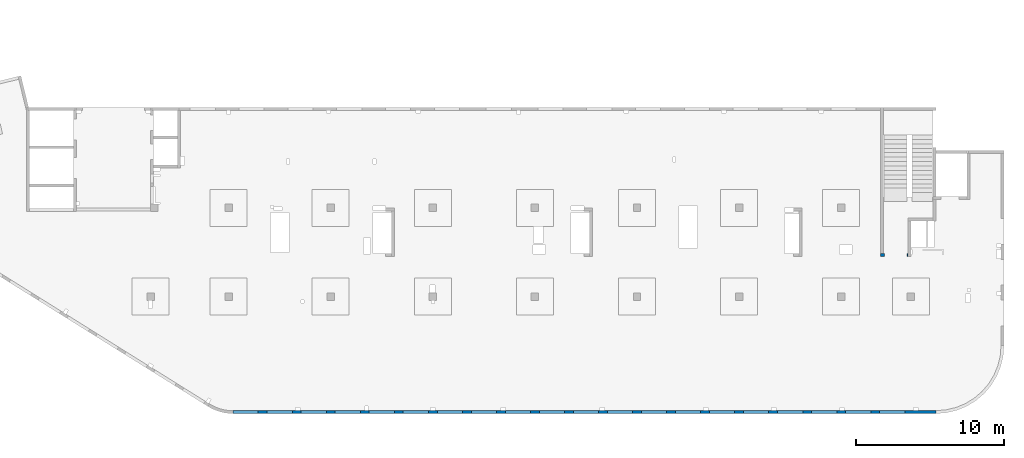
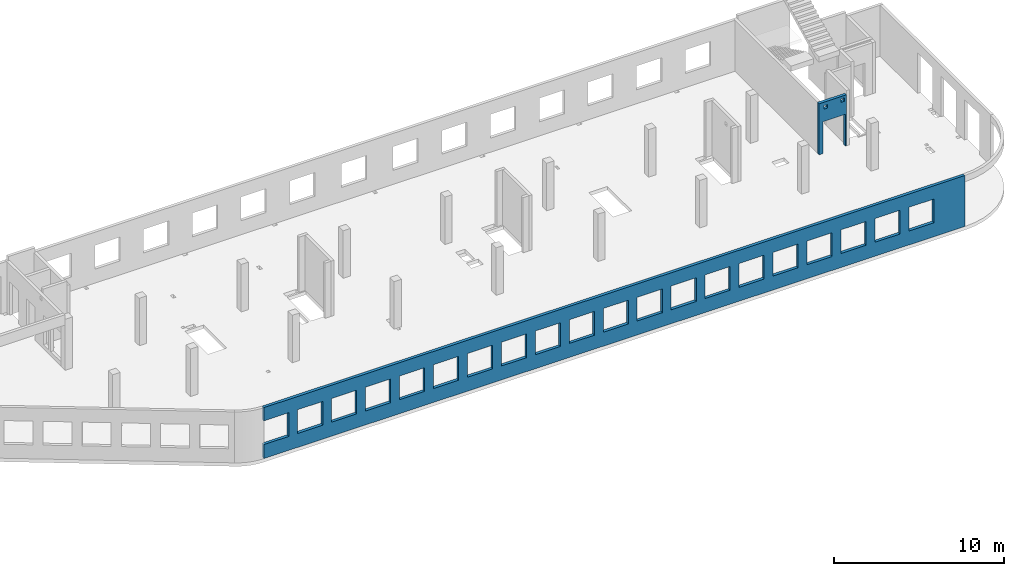
# One storey, part 91 of 93: 2 walls, 23 openings.
"""IFC4 building model written with IfcOpenShell, lengths in millimetres."""

import ifcopenshell
import ifcopenshell.guid

model = None  # the IFC model being written
_history = None  # IfcOwnerHistory: only IFC2X3 demands one
_inside = {}  # id of a spatial element -> (the spatial element, [elements in it])
_under = {}  # id of a project, library or spatial element -> (it, [spatial elements below it])
_declared = {}  # id of a project -> (the project, [libraries it declares])
_typed = {}  # id of a type object -> (the type object, [elements of that type])
_made_of = {}  # id of a material, layer set ... -> (it, [elements and type objects made of it])


def new_model(schema):
    """Start an empty IFC model of exactly this schema.

    Asked for "IFC4X3", IfcOpenShell would pick the latest addendum, in which some entities
    have other attributes; the version numbers below select the first issue.
    IFC2X3 requires an IfcOwnerHistory on every rooted entity: one is made here for all.
    """
    global model, _history
    if schema == "IFC4X3":
        model = ifcopenshell.file(schema_version=(4, 3, 0, 0))
    else:
        model = ifcopenshell.file(schema=schema)
    _inside.clear()
    _under.clear()
    _declared.clear()
    _typed.clear()
    _made_of.clear()
    _history = None
    if model.schema == "IFC2X3":
        org = make("IfcOrganization", Name="unknown")
        user = make(
            "IfcPersonAndOrganization",
            ThePerson=make("IfcPerson", FamilyName="unknown"),
            TheOrganization=org,
        )
        app = make(
            "IfcApplication",
            ApplicationDeveloper=org,
            Version="unknown",
            ApplicationFullName="unknown",
            ApplicationIdentifier="unknown",
        )
        _history = make(
            "IfcOwnerHistory",
            OwningUser=user,
            OwningApplication=app,
            ChangeAction="ADDED",
            CreationDate=0,
        )
    return model


def make(cls, **values):
    """One entity of the class cls with the attributes given. An attribute that is None is left unset."""
    return model.create_entity(
        cls, **{name: value for name, value in values.items() if value is not None}
    )


def entity(cls, *values):
    """Any entity or typed value of the class cls, its attributes in the order of the schema. None: left unset."""
    e = model.create_entity(cls)
    for i, value in enumerate(values):
        if value is not None:
            e[i] = value
    return e


def rooted(cls, **values):
    """An entity with a GlobalId (a new one), such as an element, a storey or a relation."""
    return make(cls, GlobalId=ifcopenshell.guid.new(), OwnerHistory=_history, **values)


def si_unit(unit_type, name, prefix=None):
    """IfcSIUnit, for example si_unit("LENGTHUNIT", "METRE", prefix="MILLI")."""
    return make("IfcSIUnit", UnitType=unit_type, Prefix=prefix, Name=name)


def converted_unit(unit_type, name, factor, base, dimensions=None, offset=None):
    """IfcConversionBasedUnit, such as the inch: factor (a typed value) times the base unit."""
    return make(
        "IfcConversionBasedUnit"
        if offset is None
        else "IfcConversionBasedUnitWithOffset",
        ConversionOffset=offset,
        Dimensions=None
        if dimensions is None
        else entity("IfcDimensionalExponents", *dimensions),
        UnitType=unit_type,
        Name=name,
        ConversionFactor=make(
            "IfcMeasureWithUnit", ValueComponent=factor, UnitComponent=base
        ),
    )


def derived_unit(unit_type, elements):
    """IfcDerivedUnit: a product of units, each with its exponent."""
    return make(
        "IfcDerivedUnit",
        Elements=[
            make("IfcDerivedUnitElement", Unit=unit, Exponent=power)
            for unit, power in elements
        ],
        UnitType=unit_type,
    )


def assignment(units):
    """IfcUnitAssignment: the units of a project."""
    return None if units is None else make("IfcUnitAssignment", Units=units)


def point(xyz):
    """IfcCartesianPoint."""
    return None if xyz is None else make("IfcCartesianPoint", Coordinates=xyz)


def direction(xyz):
    """IfcDirection."""
    return None if xyz is None else make("IfcDirection", DirectionRatios=xyz)


def frame(location, z_axis=None, x_axis=None):
    """IfcAxis2Placement3D, a coordinate frame: its origin and axes. An axis left out is left unset."""
    return make(
        "IfcAxis2Placement3D",
        Location=point(location),
        Axis=direction(z_axis),
        RefDirection=direction(x_axis),
    )


def origin():
    """The frame at (0, 0, 0) with its axes left unset."""
    return frame((0.0, 0.0, 0.0))


def place(relative_to, where):
    """IfcLocalPlacement: puts the frame where relative to a parent placement (None: the world)."""
    return make(
        "IfcLocalPlacement", PlacementRelTo=relative_to, RelativePlacement=where
    )


def context(
    kind, dimensions, precision=None, world=None, true_north=None, identifier=None
):
    """IfcGeometricRepresentationContext, for example the 3D "Model" context."""
    return make(
        "IfcGeometricRepresentationContext",
        ContextIdentifier=identifier,
        ContextType=kind,
        CoordinateSpaceDimension=dimensions,
        Precision=precision,
        WorldCoordinateSystem=world,
        TrueNorth=true_north,
    )


def subcontext(parent, identifier, kind, view, scale=None):
    """IfcGeometricRepresentationSubContext, for example "Body" below "Model"."""
    return make(
        "IfcGeometricRepresentationSubContext",
        ContextIdentifier=identifier,
        ContextType=kind,
        ParentContext=parent,
        TargetScale=scale,
        TargetView=view,
    )


def project(units=None, contexts=None):
    """IfcProject with its units and contexts."""
    return rooted(
        "IfcProject",
        Name="project",
        RepresentationContexts=contexts,
        UnitsInContext=assignment(units),
    )


def spatial(cls, under=None, at=None, **own):
    """A site, building, storey or space (cls), placed at a placement, below another one or the project."""
    s = rooted(cls, ObjectPlacement=at, **own)
    if under is not None:
        _under.setdefault(under.id(), (under, []))[1].append(s)
    return s


def point_list(points):
    """IfcCartesianPointList2D or 3D."""
    cls = (
        "IfcCartesianPointList2D" if len(points[0]) == 2 else "IfcCartesianPointList3D"
    )
    return make(cls, CoordList=points)


def indexed_curve(points, segments=None, self_intersect=None):
    """IfcIndexedPolyCurve: lines and arcs through numbered points (the first is 1)."""
    return make(
        "IfcIndexedPolyCurve",
        Points=point_list(points),
        Segments=segments,
        SelfIntersect=self_intersect,
    )


def outline(outer, holes=None, kind="AREA"):
    """IfcArbitraryClosedProfileDef: a profile drawn as a closed curve; with holes, ...WithVoids."""
    if holes is None:
        return make("IfcArbitraryClosedProfileDef", ProfileType=kind, OuterCurve=outer)
    return make(
        "IfcArbitraryProfileDefWithVoids",
        ProfileType=kind,
        OuterCurve=outer,
        InnerCurves=holes,
    )


def extrude(swept, where, along, depth):
    """IfcExtrudedAreaSolid: the profile swept, set in the frame where, extruded along a direction by depth."""
    return make(
        "IfcExtrudedAreaSolid",
        SweptArea=swept,
        Position=where,
        ExtrudedDirection=direction(along),
        Depth=depth,
    )


def polygons(points, faces, closed=None, point_numbers=None):
    """IfcPolygonalFaceSet: a face is its outer loop, then its inner loops; points numbered from 1."""
    made = []
    for loops in faces:
        if len(loops) == 1:
            made.append(make("IfcIndexedPolygonalFace", CoordIndex=loops[0]))
        else:
            made.append(
                make(
                    "IfcIndexedPolygonalFaceWithVoids",
                    CoordIndex=loops[0],
                    InnerCoordIndices=loops[1:],
                )
            )
    return make(
        "IfcPolygonalFaceSet",
        Coordinates=point_list(points),
        Closed=closed,
        Faces=made,
        PnIndex=point_numbers,
    )


def shape(context_of_items, identifier, shape_type, items):
    """IfcShapeRepresentation: the items that make up one representation, for example the "Body"."""
    return make(
        "IfcShapeRepresentation",
        ContextOfItems=context_of_items,
        RepresentationIdentifier=identifier,
        RepresentationType=shape_type,
        Items=items,
    )


def material(Name=None, Category=None):
    """IfcMaterial."""
    return make("IfcMaterial", Name=Name, Category=Category)


def made_of(thing, what):
    """Note that an element or type object is made of a material, layer set ...; save() writes the relation."""
    if what is not None:
        _made_of.setdefault(what.id(), (what, []))[1].append(thing)
    return thing


def type_object(cls, material=None, **own):
    """A type object (cls), such as IfcWallType, which elements share."""
    return made_of(rooted(cls, **own), material)


def element(
    cls,
    number,
    at=None,
    inside=None,
    cuts=None,
    type_object=None,
    material=None,
    context=None,
    identifier="Body",
    shape_type=None,
    held_by="IfcProductDefinitionShape",
    body=None,
    shapes=None,
    **own,
):
    """One element of the class cls, such as IfcWall. Its Tag is "e" and its number.

    at: its placement. inside: the storey or other place that contains it. cuts: it is an
    opening in that element (IfcRelVoidsElement). A single representation is given by context,
    identifier, shape_type and body (its items); several are given by shapes. held_by: the class
    of the entity that holds the representations. save() writes the other relations.
    """
    e = rooted(cls, Tag="e%d" % number, ObjectPlacement=at, **own)
    if body is not None:
        shapes = [shape(context, identifier, shape_type, body)]
    if shapes is not None:
        e.Representation = make(held_by, Representations=shapes)
    if inside is not None:
        _inside.setdefault(inside.id(), (inside, []))[1].append(e)
    if cuts is not None:
        rooted(
            "IfcRelVoidsElement", RelatingBuildingElement=cuts, RelatedOpeningElement=e
        )
    if type_object is not None:
        _typed.setdefault(type_object.id(), (type_object, []))[1].append(e)
    return made_of(e, material)


def aggregate(whole, parts):
    """IfcRelAggregates: a whole, such as a stair, and the parts it consists of."""
    return rooted("IfcRelAggregates", RelatingObject=whole, RelatedObjects=parts)


def save(model, path):
    """Write the relations noted so far, then the file.

    IfcRelAggregates (storeys below a building ...), IfcRelContainedInSpatialStructure (elements
    in a storey), IfcRelDefinesByType, IfcRelAssociatesMaterial and IfcRelDeclares: one each for
    every whole, place, type object, material and project.
    """
    for whole, parts in _under.values():
        aggregate(whole, parts)
    for where, things in _inside.values():
        rooted(
            "IfcRelContainedInSpatialStructure",
            RelatedElements=things,
            RelatingStructure=where,
        )
    for kind, things in _typed.values():
        rooted("IfcRelDefinesByType", RelatedObjects=things, RelatingType=kind)
    for what, things in _made_of.values():
        rooted("IfcRelAssociatesMaterial", RelatedObjects=things, RelatingMaterial=what)
    for by, libraries in _declared.values():
        rooted("IfcRelDeclares", RelatingContext=by, RelatedDefinitions=libraries)
    model.write(path)


model = new_model("IFC4")

# Units and contexts
model_context = context("Model", 3, precision=0.01, world=origin(), true_north=direction((6.12303176911189e-17, 1.0)))
plan_context = context("Plan", 3, precision=0.01, world=origin(), true_north=direction((6.12303176911189e-17, 1.0)))
body_context = subcontext(model_context, "Body", "Model", "MODEL_VIEW")
ifc_project = project(units=[si_unit("LENGTHUNIT", "METRE", prefix="MILLI"), si_unit("AREAUNIT", "SQUARE_METRE"), si_unit("VOLUMEUNIT", "CUBIC_METRE"), converted_unit("PLANEANGLEUNIT", "DEGREE", entity("IfcRatioMeasure", 0.0174532925199433), si_unit("PLANEANGLEUNIT", "RADIAN"), dimensions=[0, 0, 0, 0, 0, 0, 0]), si_unit("MASSUNIT", "GRAM", prefix="KILO"), derived_unit("MASSDENSITYUNIT", [(si_unit("MASSUNIT", "GRAM", prefix="KILO"), 1), (si_unit("LENGTHUNIT", "METRE"), -3)]), derived_unit("MOMENTOFINERTIAUNIT", [(si_unit("LENGTHUNIT", "METRE"), 4)]), si_unit("TIMEUNIT", "SECOND"), si_unit("FREQUENCYUNIT", "HERTZ"), si_unit("THERMODYNAMICTEMPERATUREUNIT", "DEGREE_CELSIUS"), derived_unit("THERMALTRANSMITTANCEUNIT", [(si_unit("MASSUNIT", "GRAM", prefix="KILO"), 1), (si_unit("THERMODYNAMICTEMPERATUREUNIT", "KELVIN"), -1), (si_unit("TIMEUNIT", "SECOND"), -3)]), derived_unit("VOLUMETRICFLOWRATEUNIT", [(si_unit("LENGTHUNIT", "METRE"), 3), (si_unit("TIMEUNIT", "SECOND"), -1)]), derived_unit("MASSFLOWRATEUNIT", [(si_unit("MASSUNIT", "GRAM", prefix="KILO"), 1), (si_unit("TIMEUNIT", "SECOND"), -1)]), derived_unit("ROTATIONALFREQUENCYUNIT", [(si_unit("TIMEUNIT", "SECOND"), -1)]), si_unit("ELECTRICCURRENTUNIT", "AMPERE"), si_unit("ELECTRICVOLTAGEUNIT", "VOLT"), si_unit("POWERUNIT", "WATT"), si_unit("FORCEUNIT", "NEWTON", prefix="KILO"), si_unit("ILLUMINANCEUNIT", "LUX"), si_unit("LUMINOUSFLUXUNIT", "LUMEN"), si_unit("LUMINOUSINTENSITYUNIT", "CANDELA"), derived_unit("USERDEFINED", [(si_unit("MASSUNIT", "GRAM", prefix="KILO"), -1), (si_unit("LENGTHUNIT", "METRE"), -2), (si_unit("TIMEUNIT", "SECOND"), 3), (si_unit("LUMINOUSFLUXUNIT", "LUMEN"), 1)]), derived_unit("LINEARVELOCITYUNIT", [(si_unit("LENGTHUNIT", "METRE"), 1), (si_unit("TIMEUNIT", "SECOND"), -1)]), si_unit("PRESSUREUNIT", "PASCAL"), derived_unit("USERDEFINED", [(si_unit("LENGTHUNIT", "METRE"), -2), (si_unit("MASSUNIT", "GRAM", prefix="KILO"), 1), (si_unit("TIMEUNIT", "SECOND"), -2)]), derived_unit("LINEARFORCEUNIT", [(si_unit("MASSUNIT", "GRAM", prefix="KILO"), 1), (si_unit("LENGTHUNIT", "METRE"), 1), (si_unit("TIMEUNIT", "SECOND"), -2), (si_unit("LENGTHUNIT", "METRE"), -1)]), derived_unit("PLANARFORCEUNIT", [(si_unit("MASSUNIT", "GRAM", prefix="KILO"), 1), (si_unit("LENGTHUNIT", "METRE"), 1), (si_unit("TIMEUNIT", "SECOND"), -2), (si_unit("LENGTHUNIT", "METRE"), -2)])], contexts=[model_context, plan_context])

# Site, building, storey
site_placement = place(None, origin())
site = spatial("IfcSite", under=ifc_project, at=site_placement, CompositionType="ELEMENT")
building_placement = place(site_placement, origin())
building = spatial("IfcBuilding", under=site, at=building_placement, CompositionType="ELEMENT")
storey_placement = place(building_placement, frame((0.0, 0.0, 15900.0)))
storey = spatial("IfcBuildingStorey", under=building, at=storey_placement, CompositionType="ELEMENT", Elevation=15900.0)

# Wall, openings
ifc_material = material()
wall_type = type_object("IfcWallType", PredefinedType="STANDARD")
wall_1_placement = place(storey_placement, frame((67080.0002685547, 10524.9992263555, -150.0), z_axis=(0.0, 0.0, 1.0), x_axis=(-1.0, 0.0, 0.0)))
wall_1 = element("IfcWall", 1, at=wall_1_placement, inside=storey, type_object=wall_type, material=ifc_material, PredefinedType="NOTDEFINED", context=body_context, shape_type="Tessellation", body=[
    polygons([(1849.99999999999, -100.000000000001, 3650.0), (1650.0, -100.000000000003, 3650.0), (-9.772240076716e-13, -100.000000000001, 3650.0), (-9.772240076716e-13, -100.000000000001, -2.16573425859679e-12), (74.9999999999906, -100.000000000001, -2.16573425859679e-12), (74.9999999999906, -100.000000000001, 2279.99999999805), (1575.0, -100.000000000001, 2279.99999999804), (1575.0, -100.000000000003, -2.16573425859679e-12), (1650.0, -100.000000000003, 0.0), (1849.99999999999, -100.000000000001, -2.16573425859679e-12), (125.000000000014, -100.000000000322, 3490.0), (375.000000000009, -100.000000000324, 3490.0), (375.000000000009, -100.000000000324, 3240.00000000001), (125.000000000014, -100.000000000322, 3240.00000000001), (1275.0, -100.000000000322, 3400.0), (1524.99999999999, -100.000000000322, 3400.0), (1524.99999999999, -100.000000000322, 3150.00000000001), (1275.0, -100.000000000322, 3150.00000000001), (-1.61109744921212e-12, 99.9999999999989, 3650.0), (1849.99999999999, 99.9999999999989, 3650.0), (1849.99999999999, 99.9999999999989, -2.16573425859679e-12), (1575.0, 99.9999999999968, -2.16573425859679e-12), (1575.0, 99.9999999999968, 2279.99999999804), (74.99999999999, 99.9999999999989, 2279.99999999805), (74.99999999999, 99.9999999999989, -2.16573425859679e-12), (-1.61109744921212e-12, 99.9999999999989, -2.16573425859679e-12), (375.000000000008, 99.9999999999968, 3490.0), (125.000000000013, 99.9999999999968, 3490.0), (125.000000000013, 99.9999999999968, 3240.00000000001), (375.000000000008, 99.9999999999968, 3240.00000000001), (1524.99999999999, 99.9999999999968, 3400.0), (1275.0, 99.9999999999989, 3400.0), (1275.0, 99.9999999999989, 3150.00000000001), (1524.99999999999, 99.9999999999968, 3150.00000000001)], [[[1, 2, 3, 4, 5, 6, 7, 8, 9, 10], [11, 12, 13, 14], [15, 16, 17, 18]], [[19, 20, 21, 22, 23, 24, 25, 26], [27, 28, 29, 30], [31, 32, 33, 34]], [[4, 26, 25, 5]], [[3, 2, 1, 20, 19]], [[4, 3, 19, 26]], [[1, 10, 21, 20]], [[12, 11, 28, 27]], [[12, 27, 30, 13]], [[13, 30, 29, 14]], [[28, 11, 14, 29]], [[16, 15, 32, 31]], [[16, 31, 34, 17]], [[17, 34, 33, 18]], [[32, 15, 18, 33]], [[6, 24, 23, 7]], [[7, 23, 22, 8]], [[24, 6, 5, 25]], [[21, 10, 9, 8, 22]]], closed=True),
])
opening_1_placement = place(wall_1_placement, frame((67080.0002685547, 10524.9992263555, 150.0), z_axis=(0.0, 0.0, 1.0), x_axis=(-1.0, 0.0, 0.0)))
element("IfcOpeningElement", 2, at=opening_1_placement, cuts=wall_1, PredefinedType="OPENING", context=body_context, shape_type="SweptSolid", body=[
    extrude(outline(indexed_curve([(-750.000000000003, -1139.99999999902), (749.999999999994, -1139.99999999902), (749.999999999994, 1139.99999999902), (-750.000000000003, 1139.99999999902), (-750.000000000003, -1139.99999999902)], self_intersect=False)), frame((66255.0002685547, 10724.9992263575, 990.0), z_axis=(0.0, -1.0, 0.0), x_axis=(-1.0, 0.0, 0.0)), (0.0, 0.0, 1.0), 400.000000001943),
])
opening_2_placement = place(wall_1_placement, frame((67080.0002685547, 10524.9992263555, 150.0), z_axis=(0.0, 0.0, 1.0), x_axis=(-1.0, 0.0, 0.0)))
element("IfcOpeningElement", 3, at=opening_2_placement, cuts=wall_1, PredefinedType="OPENING", context=body_context, shape_type="SweptSolid", body=[
    extrude(outline(indexed_curve([(-125.000000000006, -124.999999999993), (124.999999999998, -124.999999999993), (124.999999999998, 124.999999999993), (-125.000000000006, 124.999999999993), (-125.000000000006, -124.999999999993)], self_intersect=False)), frame((65680.0002685547, 10624.9992263565, 3125.0), z_axis=(0.0, -1.0, 0.0), x_axis=(-1.0, 0.0, 0.0)), (0.0, 0.0, 1.0), 200.000000000962),
])
opening_3_placement = place(wall_1_placement, frame((67080.0002685547, 10524.9992263555, 150.0), z_axis=(0.0, 0.0, 1.0), x_axis=(-1.0, 0.0, 0.0)))
element("IfcOpeningElement", 4, at=opening_3_placement, cuts=wall_1, PredefinedType="OPENING", context=body_context, shape_type="SweptSolid", body=[
    extrude(outline(indexed_curve([(-125.000000000006, -124.999999999993), (124.999999999998, -124.999999999993), (124.999999999998, 124.999999999993), (-125.000000000006, 124.999999999993), (-125.000000000006, -124.999999999993)], self_intersect=False)), frame((66830.0002685547, 10624.9992263565, 3215.0), z_axis=(0.0, -1.0, 0.0), x_axis=(-1.0, 0.0, 0.0)), (0.0, 0.0, 1.0), 200.000000000962),
])

wall_2_placement = place(storey_placement, frame((68970.0002685547, -99.9999557734324, -150.0), z_axis=(0.0, 0.0, 1.0), x_axis=(-1.0, 0.0, 0.0)))
wall_2 = element("IfcWall", 5, at=wall_2_placement, inside=storey, type_object=wall_type, material=ifc_material, PredefinedType="NOTDEFINED", context=body_context, shape_type="Tessellation", body=[
    polygons([(8.66293717728731e-12, -100.0, -2.16573425859679e-12), (47500.0, -100.0, -2.16573425859679e-12), (47500.0, -100.0, 1000.00000000001), (45800.0, -100.000000000321, 1000.00000000001), (45800.0, -100.000000000321, 2700.0), (47500.0, -100.0, 2700.0), (47500.0, -100.0, 3650.0), (8.66293717728731e-12, -100.0, 3650.0), (1.42900165493394e-19, -100.0, 3200.0), (43500.0, -100.000000000321, 2700.0), (45200.0, -100.000000000321, 2700.0), (45200.0, -100.000000000321, 1000.00000000001), (43500.0, -100.000000000321, 1000.00000000001), (41200.0, -100.000000000321, 2700.0), (42900.0, -100.000000000321, 2700.0), (42900.0, -100.000000000321, 1000.00000000001), (41200.0, -100.000000000321, 1000.00000000001), (38900.0, -100.000000000321, 2700.0), (40600.0, -100.000000000321, 2700.0), (40600.0, -100.000000000321, 1000.00000000001), (38900.0, -100.000000000321, 1000.00000000001), (36600.0, -100.000000000321, 2700.0), (38300.0, -100.000000000321, 2700.0), (38300.0, -100.000000000321, 1000.00000000001), (36600.0, -100.000000000321, 1000.00000000001), (34300.0, -100.000000000321, 2700.0), (36000.0, -100.000000000321, 2700.0), (36000.0, -100.000000000321, 1000.00000000001), (34300.0, -100.000000000321, 1000.00000000001), (32000.0, -100.000000000321, 2700.0), (33700.0, -100.000000000321, 2700.0), (33700.0, -100.000000000321, 1000.00000000001), (32000.0, -100.000000000321, 1000.00000000001), (29700.0, -100.000000000321, 2700.0), (31400.0, -100.000000000321, 2700.0), (31400.0, -100.000000000321, 1000.00000000001), (29700.0, -100.000000000321, 1000.00000000001), (27400.0, -100.000000000321, 2700.0), (29100.0, -100.000000000321, 2700.0), (29100.0, -100.000000000321, 1000.00000000001), (27400.0, -100.000000000321, 1000.00000000001), (25100.0, -100.000000000321, 2700.0), (26800.0, -100.000000000321, 2700.0), (26800.0, -100.000000000321, 1000.00000000001), (25100.0, -100.000000000321, 1000.00000000001), (22800.0, -100.000000000321, 2700.0), (24500.0, -100.000000000321, 2700.0), (24500.0, -100.000000000321, 1000.00000000001), (22800.0, -100.000000000321, 1000.00000000001), (20500.0, -100.000000000321, 2700.0), (22200.0, -100.000000000321, 2700.0), (22200.0, -100.000000000321, 1000.00000000001), (20500.0, -100.000000000321, 1000.00000000001), (18200.0, -100.000000000321, 2700.0), (19900.0, -100.000000000321, 2700.0), (19900.0, -100.000000000321, 1000.00000000001), (18200.0, -100.000000000321, 1000.00000000001), (15900.0, -100.000000000321, 2700.0), (17600.0, -100.000000000321, 2700.0), (17600.0, -100.000000000321, 1000.00000000001), (15900.0, -100.000000000321, 1000.00000000001), (13600.0, -100.000000000321, 2700.0), (15300.0, -100.000000000321, 2700.0), (15300.0, -100.000000000321, 1000.00000000001), (13600.0, -100.000000000321, 1000.00000000001), (11300.0, -100.000000000321, 2700.0), (13000.0, -100.000000000321, 2700.0), (13000.0, -100.000000000321, 1000.00000000001), (11300.0, -100.000000000321, 1000.00000000001), (8999.99999999998, -100.000000000321, 2700.0), (10700.0, -100.000000000321, 2700.0), (10700.0, -100.000000000321, 1000.00000000001), (8999.99999999998, -100.000000000321, 1000.00000000001), (6699.99999999998, -100.000000000321, 2700.0), (8399.99999999997, -100.000000000321, 2700.0), (8399.99999999997, -100.000000000321, 1000.00000000001), (6699.99999999998, -100.000000000321, 1000.00000000001), (4399.99999999998, -100.000000000321, 2700.0), (6099.99999999997, -100.000000000321, 2700.0), (6099.99999999997, -100.000000000321, 1000.00000000001), (4399.99999999998, -100.000000000321, 1000.00000000001), (2099.99999999998, -100.000000000321, 2700.0), (3799.99999999998, -100.000000000321, 2700.0), (3799.99999999998, -100.000000000321, 1000.00000000001), (2099.99999999998, -100.000000000321, 1000.00000000001), (47500.0, 100.0, -2.16573425859679e-12), (8.01671852045731e-12, 100.0, -2.16573425859679e-12), (-6.46218513929826e-13, 100.0, 3200.0), (8.01671852045731e-12, 100.0, 3650.0), (47500.0, 100.0, 3650.0), (47500.0, 100.0, 2700.0), (45800.0, 100.0, 2700.0), (45800.0, 100.0, 1000.00000000001), (47500.0, 100.0, 1000.00000000001), (45200.0, 100.0, 2700.0), (43500.0, 100.0, 2700.0), (43500.0, 100.0, 1000.00000000001), (45200.0, 100.0, 1000.00000000001), (42900.0, 100.0, 2700.0), (41200.0, 100.0, 2700.0), (41200.0, 100.0, 1000.00000000001), (42900.0, 100.0, 1000.00000000001), (40600.0, 100.0, 2700.0), (38900.0, 100.0, 2700.0), (38900.0, 100.0, 1000.00000000001), (40600.0, 100.0, 1000.00000000001), (38300.0, 100.0, 2700.0), (36600.0, 100.0, 2700.0), (36600.0, 100.0, 1000.00000000001), (38300.0, 100.0, 1000.00000000001), (36000.0, 100.0, 2700.0), (34300.0, 100.0, 2700.0), (34300.0, 100.0, 1000.00000000001), (36000.0, 100.0, 1000.00000000001), (33700.0, 100.0, 2700.0), (32000.0, 100.0, 2700.0), (32000.0, 100.0, 1000.00000000001), (33700.0, 100.0, 1000.00000000001), (31400.0, 100.0, 2700.0), (29700.0, 100.0, 2700.0), (29700.0, 100.0, 1000.00000000001), (31400.0, 100.0, 1000.00000000001), (29100.0, 100.0, 2700.0), (27400.0, 100.0, 2700.0), (27400.0, 100.0, 1000.00000000001), (29100.0, 100.0, 1000.00000000001), (26800.0, 100.0, 2700.0), (25100.0, 100.0, 2700.0), (25100.0, 100.0, 1000.00000000001), (26800.0, 100.0, 1000.00000000001), (24500.0, 100.0, 2700.0), (22800.0, 100.0, 2700.0), (22800.0, 100.0, 1000.00000000001), (24500.0, 100.0, 1000.00000000001), (22200.0, 100.0, 2700.0), (20500.0, 100.0, 2700.0), (20500.0, 100.0, 1000.00000000001), (22200.0, 100.0, 1000.00000000001), (19900.0, 100.0, 2700.0), (18200.0, 100.0, 2700.0), (18200.0, 100.0, 1000.00000000001), (19900.0, 100.0, 1000.00000000001), (17600.0, 100.0, 2700.0), (15900.0, 100.0, 2700.0), (15900.0, 100.0, 1000.00000000001), (17600.0, 100.0, 1000.00000000001), (15300.0, 100.0, 2700.0), (13600.0, 100.0, 2700.0), (13600.0, 100.0, 1000.00000000001), (15300.0, 100.0, 1000.00000000001), (13000.0, 100.0, 2700.0), (11300.0, 100.0, 2700.0), (11300.0, 100.0, 1000.00000000001), (13000.0, 100.0, 1000.00000000001), (10700.0, 100.0, 2700.0), (8999.99999999998, 100.0, 2700.0), (8999.99999999998, 100.0, 1000.00000000001), (10700.0, 100.0, 1000.00000000001), (8399.99999999997, 100.0, 2700.0), (6699.99999999997, 100.0, 2700.0), (6699.99999999997, 100.0, 1000.00000000001), (8399.99999999997, 100.0, 1000.00000000001), (6099.99999999997, 100.0, 2700.0), (4399.99999999998, 100.0, 2700.0), (4399.99999999998, 100.0, 1000.00000000001), (6099.99999999997, 100.0, 1000.00000000001), (3799.99999999998, 100.0, 2700.0), (2099.99999999998, 100.0, 2700.0), (2099.99999999998, 100.0, 1000.00000000001), (3799.99999999998, 100.0, 1000.00000000001)], [[[1, 2, 3, 4, 5, 6, 7, 8, 9], [10, 11, 12, 13], [14, 15, 16, 17], [18, 19, 20, 21], [22, 23, 24, 25], [26, 27, 28, 29], [30, 31, 32, 33], [34, 35, 36, 37], [38, 39, 40, 41], [42, 43, 44, 45], [46, 47, 48, 49], [50, 51, 52, 53], [54, 55, 56, 57], [58, 59, 60, 61], [62, 63, 64, 65], [66, 67, 68, 69], [70, 71, 72, 73], [74, 75, 76, 77], [78, 79, 80, 81], [82, 83, 84, 85]], [[86, 87, 88, 89, 90, 91, 92, 93, 94], [95, 96, 97, 98], [99, 100, 101, 102], [103, 104, 105, 106], [107, 108, 109, 110], [111, 112, 113, 114], [115, 116, 117, 118], [119, 120, 121, 122], [123, 124, 125, 126], [127, 128, 129, 130], [131, 132, 133, 134], [135, 136, 137, 138], [139, 140, 141, 142], [143, 144, 145, 146], [147, 148, 149, 150], [151, 152, 153, 154], [155, 156, 157, 158], [159, 160, 161, 162], [163, 164, 165, 166], [167, 168, 169, 170]], [[2, 1, 87, 86]], [[2, 86, 94, 3]], [[8, 7, 90, 89]], [[1, 9, 8, 89, 88, 87]], [[5, 92, 91, 6]], [[93, 4, 3, 94]], [[92, 5, 4, 93]], [[11, 10, 96, 95]], [[11, 95, 98, 12]], [[12, 98, 97, 13]], [[96, 10, 13, 97]], [[15, 14, 100, 99]], [[15, 99, 102, 16]], [[16, 102, 101, 17]], [[100, 14, 17, 101]], [[19, 18, 104, 103]], [[19, 103, 106, 20]], [[20, 106, 105, 21]], [[104, 18, 21, 105]], [[23, 22, 108, 107]], [[23, 107, 110, 24]], [[24, 110, 109, 25]], [[108, 22, 25, 109]], [[27, 26, 112, 111]], [[27, 111, 114, 28]], [[28, 114, 113, 29]], [[112, 26, 29, 113]], [[31, 30, 116, 115]], [[31, 115, 118, 32]], [[32, 118, 117, 33]], [[116, 30, 33, 117]], [[35, 34, 120, 119]], [[35, 119, 122, 36]], [[36, 122, 121, 37]], [[120, 34, 37, 121]], [[39, 38, 124, 123]], [[39, 123, 126, 40]], [[40, 126, 125, 41]], [[124, 38, 41, 125]], [[43, 42, 128, 127]], [[43, 127, 130, 44]], [[44, 130, 129, 45]], [[128, 42, 45, 129]], [[47, 46, 132, 131]], [[47, 131, 134, 48]], [[48, 134, 133, 49]], [[132, 46, 49, 133]], [[51, 50, 136, 135]], [[51, 135, 138, 52]], [[52, 138, 137, 53]], [[136, 50, 53, 137]], [[55, 54, 140, 139]], [[55, 139, 142, 56]], [[56, 142, 141, 57]], [[140, 54, 57, 141]], [[59, 58, 144, 143]], [[59, 143, 146, 60]], [[60, 146, 145, 61]], [[144, 58, 61, 145]], [[63, 62, 148, 147]], [[63, 147, 150, 64]], [[64, 150, 149, 65]], [[148, 62, 65, 149]], [[67, 66, 152, 151]], [[67, 151, 154, 68]], [[68, 154, 153, 69]], [[152, 66, 69, 153]], [[71, 70, 156, 155]], [[71, 155, 158, 72]], [[72, 158, 157, 73]], [[156, 70, 73, 157]], [[75, 74, 160, 159]], [[75, 159, 162, 76]], [[76, 162, 161, 77]], [[160, 74, 77, 161]], [[79, 78, 164, 163]], [[79, 163, 166, 80]], [[80, 166, 165, 81]], [[164, 78, 81, 165]], [[83, 82, 168, 167]], [[83, 167, 170, 84]], [[84, 170, 169, 85]], [[168, 82, 85, 169]], [[90, 7, 6, 91]]], closed=True),
])
opening_4_placement = place(wall_2_placement, frame((68970.0002685547, -99.9999557734324, 150.0), z_axis=(0.0, 0.0, 1.0), x_axis=(-1.0, 0.0, 0.0)))
element("IfcOpeningElement", 6, at=opening_4_placement, cuts=wall_2, PredefinedType="OPENING", context=body_context, shape_type="SweptSolid", body=[
    extrude(outline(indexed_curve([(-850.000000000002, -849.999999999993), (849.999999999997, -849.999999999993), (849.999999999997, 849.999999999995), (-850.000000000002, 849.999999999995), (-850.000000000002, -849.999999999993)], self_intersect=False)), frame((22320.0002685547, 4.42276800359536e-05, 1700.0), z_axis=(0.0, -1.0, 0.0), x_axis=(-1.0, 0.0, 0.0)), (0.0, 0.0, 1.0), 200.000000000962),
])
opening_5_placement = place(wall_2_placement, frame((68970.0002685547, -99.9999557734324, 150.0), z_axis=(0.0, 0.0, 1.0), x_axis=(-1.0, 0.0, 0.0)))
element("IfcOpeningElement", 7, at=opening_5_placement, cuts=wall_2, PredefinedType="OPENING", context=body_context, shape_type="SweptSolid", body=[
    extrude(outline(indexed_curve([(-849.999999999997, -849.999999999993), (850.000000000006, -849.999999999993), (850.000000000006, 849.999999999995), (-849.999999999997, 849.999999999995), (-849.999999999997, -849.999999999993)], self_intersect=False)), frame((66020.0002685547, 4.4227538823312e-05, 1700.0), z_axis=(0.0, -1.0, 0.0), x_axis=(-1.0, 0.0, 0.0)), (0.0, 0.0, 1.0), 200.000000000962),
])
opening_6_placement = place(wall_2_placement, frame((68970.0002685547, -99.9999557734324, 150.0), z_axis=(0.0, 0.0, 1.0), x_axis=(-1.0, 0.0, 0.0)))
element("IfcOpeningElement", 8, at=opening_6_placement, cuts=wall_2, PredefinedType="OPENING", context=body_context, shape_type="SweptSolid", body=[
    extrude(outline(indexed_curve([(-849.999999999997, -849.999999999993), (850.000000000006, -849.999999999993), (850.000000000006, 849.999999999995), (-849.999999999997, 849.999999999995), (-849.999999999997, -849.999999999993)], self_intersect=False)), frame((63720.0002685547, 4.42275462680235e-05, 1700.0), z_axis=(0.0, -1.0, 0.0), x_axis=(-1.0, 0.0, 0.0)), (0.0, 0.0, 1.0), 200.000000000962),
])
opening_7_placement = place(wall_2_placement, frame((68970.0002685547, -99.9999557734324, 150.0), z_axis=(0.0, 0.0, 1.0), x_axis=(-1.0, 0.0, 0.0)))
element("IfcOpeningElement", 9, at=opening_7_placement, cuts=wall_2, PredefinedType="OPENING", context=body_context, shape_type="SweptSolid", body=[
    extrude(outline(indexed_curve([(-849.999999999997, -849.999999999993), (850.000000000006, -849.999999999993), (850.000000000006, 849.999999999995), (-849.999999999997, 849.999999999995), (-849.999999999997, -849.999999999993)], self_intersect=False)), frame((61420.0002685547, 4.42275536958152e-05, 1700.0), z_axis=(0.0, -1.0, 0.0), x_axis=(-1.0, 0.0, 0.0)), (0.0, 0.0, 1.0), 200.000000000962),
])
opening_8_placement = place(wall_2_placement, frame((68970.0002685547, -99.9999557734324, 150.0), z_axis=(0.0, 0.0, 1.0), x_axis=(-1.0, 0.0, 0.0)))
element("IfcOpeningElement", 10, at=opening_8_placement, cuts=wall_2, PredefinedType="OPENING", context=body_context, shape_type="SweptSolid", body=[
    extrude(outline(indexed_curve([(-849.999999999997, -849.999999999993), (850.000000000006, -849.999999999993), (850.000000000006, 849.999999999995), (-849.999999999997, 849.999999999995), (-849.999999999997, -849.999999999993)], self_intersect=False)), frame((59120.0002685547, 4.4227561123607e-05, 1700.0), z_axis=(0.0, -1.0, 0.0), x_axis=(-1.0, 0.0, 0.0)), (0.0, 0.0, 1.0), 200.000000000962),
])
opening_9_placement = place(wall_2_placement, frame((68970.0002685547, -99.9999557734324, 150.0), z_axis=(0.0, 0.0, 1.0), x_axis=(-1.0, 0.0, 0.0)))
element("IfcOpeningElement", 11, at=opening_9_placement, cuts=wall_2, PredefinedType="OPENING", context=body_context, shape_type="SweptSolid", body=[
    extrude(outline(indexed_curve([(-849.999999999997, -849.999999999993), (850.000000000006, -849.999999999993), (850.000000000006, 849.999999999995), (-849.999999999997, 849.999999999995), (-849.999999999997, -849.999999999993)], self_intersect=False)), frame((56820.0002685547, 4.42275685513987e-05, 1700.0), z_axis=(0.0, -1.0, 0.0), x_axis=(-1.0, 0.0, 0.0)), (0.0, 0.0, 1.0), 200.000000000962),
])
opening_10_placement = place(wall_2_placement, frame((68970.0002685547, -99.9999557734324, 150.0), z_axis=(0.0, 0.0, 1.0), x_axis=(-1.0, 0.0, 0.0)))
element("IfcOpeningElement", 12, at=opening_10_placement, cuts=wall_2, PredefinedType="OPENING", context=body_context, shape_type="SweptSolid", body=[
    extrude(outline(indexed_curve([(-849.999999999997, -849.999999999993), (850.000000000006, -849.999999999993), (850.000000000006, 849.999999999995), (-849.999999999997, 849.999999999995), (-849.999999999997, -849.999999999993)], self_intersect=False)), frame((54520.0002685547, 4.42275759791904e-05, 1700.0), z_axis=(0.0, -1.0, 0.0), x_axis=(-1.0, 0.0, 0.0)), (0.0, 0.0, 1.0), 200.000000000962),
])
opening_11_placement = place(wall_2_placement, frame((68970.0002685547, -99.9999557734324, 150.0), z_axis=(0.0, 0.0, 1.0), x_axis=(-1.0, 0.0, 0.0)))
element("IfcOpeningElement", 13, at=opening_11_placement, cuts=wall_2, PredefinedType="OPENING", context=body_context, shape_type="SweptSolid", body=[
    extrude(outline(indexed_curve([(-849.999999999997, -849.999999999993), (850.000000000006, -849.999999999993), (850.000000000006, 849.999999999995), (-849.999999999997, 849.999999999995), (-849.999999999997, -849.999999999993)], self_intersect=False)), frame((52220.0002685547, 4.42275834239019e-05, 1700.0), z_axis=(0.0, -1.0, 0.0), x_axis=(-1.0, 0.0, 0.0)), (0.0, 0.0, 1.0), 200.000000000962),
])
opening_12_placement = place(wall_2_placement, frame((68970.0002685547, -99.9999557734324, 150.0), z_axis=(0.0, 0.0, 1.0), x_axis=(-1.0, 0.0, 0.0)))
element("IfcOpeningElement", 14, at=opening_12_placement, cuts=wall_2, PredefinedType="OPENING", context=body_context, shape_type="SweptSolid", body=[
    extrude(outline(indexed_curve([(-849.999999999997, -849.999999999993), (850.000000000006, -849.999999999993), (850.000000000006, 849.999999999995), (-849.999999999997, 849.999999999995), (-849.999999999997, -849.999999999993)], self_intersect=False)), frame((49920.0002685547, 4.42275908516936e-05, 1700.0), z_axis=(0.0, -1.0, 0.0), x_axis=(-1.0, 0.0, 0.0)), (0.0, 0.0, 1.0), 200.000000000962),
])
opening_13_placement = place(wall_2_placement, frame((68970.0002685547, -99.9999557734324, 150.0), z_axis=(0.0, 0.0, 1.0), x_axis=(-1.0, 0.0, 0.0)))
element("IfcOpeningElement", 15, at=opening_13_placement, cuts=wall_2, PredefinedType="OPENING", context=body_context, shape_type="SweptSolid", body=[
    extrude(outline(indexed_curve([(-849.999999999997, -849.999999999993), (850.000000000006, -849.999999999993), (850.000000000006, 849.999999999995), (-849.999999999997, 849.999999999995), (-849.999999999997, -849.999999999993)], self_intersect=False)), frame((47620.0002685547, 4.42275982794853e-05, 1700.0), z_axis=(0.0, -1.0, 0.0), x_axis=(-1.0, 0.0, 0.0)), (0.0, 0.0, 1.0), 200.000000000962),
])
opening_14_placement = place(wall_2_placement, frame((68970.0002685547, -99.9999557734324, 150.0), z_axis=(0.0, 0.0, 1.0), x_axis=(-1.0, 0.0, 0.0)))
element("IfcOpeningElement", 16, at=opening_14_placement, cuts=wall_2, PredefinedType="OPENING", context=body_context, shape_type="SweptSolid", body=[
    extrude(outline(indexed_curve([(-849.999999999997, -849.999999999993), (850.000000000006, -849.999999999993), (850.000000000006, 849.999999999995), (-849.999999999997, 849.999999999995), (-849.999999999997, -849.999999999993)], self_intersect=False)), frame((45320.0002685547, 4.4227605707277e-05, 1700.0), z_axis=(0.0, -1.0, 0.0), x_axis=(-1.0, 0.0, 0.0)), (0.0, 0.0, 1.0), 200.000000000962),
])
opening_15_placement = place(wall_2_placement, frame((68970.0002685547, -99.9999557734324, 150.0), z_axis=(0.0, 0.0, 1.0), x_axis=(-1.0, 0.0, 0.0)))
element("IfcOpeningElement", 17, at=opening_15_placement, cuts=wall_2, PredefinedType="OPENING", context=body_context, shape_type="SweptSolid", body=[
    extrude(outline(indexed_curve([(-849.999999999997, -849.999999999993), (850.000000000006, -849.999999999993), (850.000000000006, 849.999999999995), (-849.999999999997, 849.999999999995), (-849.999999999997, -849.999999999993)], self_intersect=False)), frame((43020.0002685547, 4.42276131519886e-05, 1700.0), z_axis=(0.0, -1.0, 0.0), x_axis=(-1.0, 0.0, 0.0)), (0.0, 0.0, 1.0), 200.000000000962),
])
opening_16_placement = place(wall_2_placement, frame((68970.0002685547, -99.9999557734324, 150.0), z_axis=(0.0, 0.0, 1.0), x_axis=(-1.0, 0.0, 0.0)))
element("IfcOpeningElement", 18, at=opening_16_placement, cuts=wall_2, PredefinedType="OPENING", context=body_context, shape_type="SweptSolid", body=[
    extrude(outline(indexed_curve([(-849.999999999997, -849.999999999993), (850.000000000006, -849.999999999993), (850.000000000006, 849.999999999995), (-849.999999999997, 849.999999999995), (-849.999999999997, -849.999999999993)], self_intersect=False)), frame((40720.0002685547, 4.42276205797803e-05, 1700.0), z_axis=(0.0, -1.0, 0.0), x_axis=(-1.0, 0.0, 0.0)), (0.0, 0.0, 1.0), 200.000000000962),
])
opening_17_placement = place(wall_2_placement, frame((68970.0002685547, -99.9999557734324, 150.0), z_axis=(0.0, 0.0, 1.0), x_axis=(-1.0, 0.0, 0.0)))
element("IfcOpeningElement", 19, at=opening_17_placement, cuts=wall_2, PredefinedType="OPENING", context=body_context, shape_type="SweptSolid", body=[
    extrude(outline(indexed_curve([(-849.999999999997, -849.999999999993), (850.000000000002, -849.999999999993), (850.000000000002, 849.999999999995), (-849.999999999997, 849.999999999995), (-849.999999999997, -849.999999999993)], self_intersect=False)), frame((38420.0002685547, 4.4227628007572e-05, 1700.0), z_axis=(0.0, -1.0, 0.0), x_axis=(-1.0, 0.0, 0.0)), (0.0, 0.0, 1.0), 200.000000000962),
])
opening_18_placement = place(wall_2_placement, frame((68970.0002685547, -99.9999557734324, 150.0), z_axis=(0.0, 0.0, 1.0), x_axis=(-1.0, 0.0, 0.0)))
element("IfcOpeningElement", 20, at=opening_18_placement, cuts=wall_2, PredefinedType="OPENING", context=body_context, shape_type="SweptSolid", body=[
    extrude(outline(indexed_curve([(-849.999999999997, -849.999999999993), (850.000000000002, -849.999999999993), (850.000000000002, 849.999999999995), (-849.999999999997, 849.999999999995), (-849.999999999997, -849.999999999993)], self_intersect=False)), frame((36120.0002685547, 4.42276354353637e-05, 1700.0), z_axis=(0.0, -1.0, 0.0), x_axis=(-1.0, 0.0, 0.0)), (0.0, 0.0, 1.0), 200.000000000962),
])
opening_19_placement = place(wall_2_placement, frame((68970.0002685547, -99.9999557734324, 150.0), z_axis=(0.0, 0.0, 1.0), x_axis=(-1.0, 0.0, 0.0)))
element("IfcOpeningElement", 21, at=opening_19_placement, cuts=wall_2, PredefinedType="OPENING", context=body_context, shape_type="SweptSolid", body=[
    extrude(outline(indexed_curve([(-849.999999999997, -849.999999999993), (850.000000000002, -849.999999999993), (850.000000000002, 849.999999999995), (-849.999999999997, 849.999999999995), (-849.999999999997, -849.999999999993)], self_intersect=False)), frame((33820.0002685547, 4.42276428631554e-05, 1700.0), z_axis=(0.0, -1.0, 0.0), x_axis=(-1.0, 0.0, 0.0)), (0.0, 0.0, 1.0), 200.000000000962),
])
opening_20_placement = place(wall_2_placement, frame((68970.0002685547, -99.9999557734324, 150.0), z_axis=(0.0, 0.0, 1.0), x_axis=(-1.0, 0.0, 0.0)))
element("IfcOpeningElement", 22, at=opening_20_placement, cuts=wall_2, PredefinedType="OPENING", context=body_context, shape_type="SweptSolid", body=[
    extrude(outline(indexed_curve([(-849.999999999997, -849.999999999993), (850.000000000002, -849.999999999993), (850.000000000002, 849.999999999995), (-849.999999999997, 849.999999999995), (-849.999999999997, -849.999999999993)], self_intersect=False)), frame((31520.0002685547, 4.42276503078669e-05, 1700.0), z_axis=(0.0, -1.0, 0.0), x_axis=(-1.0, 0.0, 0.0)), (0.0, 0.0, 1.0), 200.000000000962),
])
opening_21_placement = place(wall_2_placement, frame((68970.0002685547, -99.9999557734324, 150.0), z_axis=(0.0, 0.0, 1.0), x_axis=(-1.0, 0.0, 0.0)))
element("IfcOpeningElement", 23, at=opening_21_placement, cuts=wall_2, PredefinedType="OPENING", context=body_context, shape_type="SweptSolid", body=[
    extrude(outline(indexed_curve([(-850.000000000002, -849.999999999993), (849.999999999997, -849.999999999993), (849.999999999997, 849.999999999995), (-850.000000000002, 849.999999999995), (-850.000000000002, -849.999999999993)], self_intersect=False)), frame((29220.0002685547, 4.42276577356586e-05, 1700.0), z_axis=(0.0, -1.0, 0.0), x_axis=(-1.0, 0.0, 0.0)), (0.0, 0.0, 1.0), 200.000000000962),
])
opening_22_placement = place(wall_2_placement, frame((68970.0002685547, -99.9999557734324, 150.0), z_axis=(0.0, 0.0, 1.0), x_axis=(-1.0, 0.0, 0.0)))
element("IfcOpeningElement", 24, at=opening_22_placement, cuts=wall_2, PredefinedType="OPENING", context=body_context, shape_type="SweptSolid", body=[
    extrude(outline(indexed_curve([(-850.000000000002, -849.999999999993), (849.999999999997, -849.999999999993), (849.999999999997, 849.999999999995), (-850.000000000002, 849.999999999995), (-850.000000000002, -849.999999999993)], self_intersect=False)), frame((26920.0002685547, 4.42276651634504e-05, 1700.0), z_axis=(0.0, -1.0, 0.0), x_axis=(-1.0, 0.0, 0.0)), (0.0, 0.0, 1.0), 200.000000000962),
])
opening_23_placement = place(wall_2_placement, frame((68970.0002685547, -99.9999557734324, 150.0), z_axis=(0.0, 0.0, 1.0), x_axis=(-1.0, 0.0, 0.0)))
element("IfcOpeningElement", 25, at=opening_23_placement, cuts=wall_2, PredefinedType="OPENING", context=body_context, shape_type="SweptSolid", body=[
    extrude(outline(indexed_curve([(-850.000000000002, -849.999999999993), (849.999999999997, -849.999999999993), (849.999999999997, 849.999999999995), (-850.000000000002, 849.999999999995), (-850.000000000002, -849.999999999993)], self_intersect=False)), frame((24620.0002685547, 4.42276725912421e-05, 1700.0), z_axis=(0.0, -1.0, 0.0), x_axis=(-1.0, 0.0, 0.0)), (0.0, 0.0, 1.0), 200.000000000962),
])

save(model, "model.ifc")
